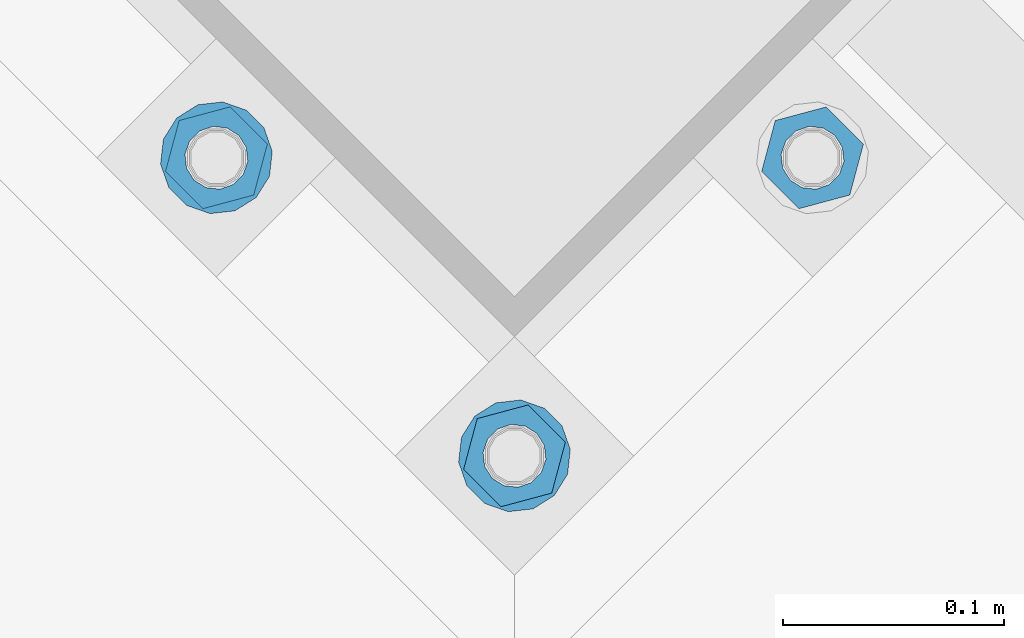
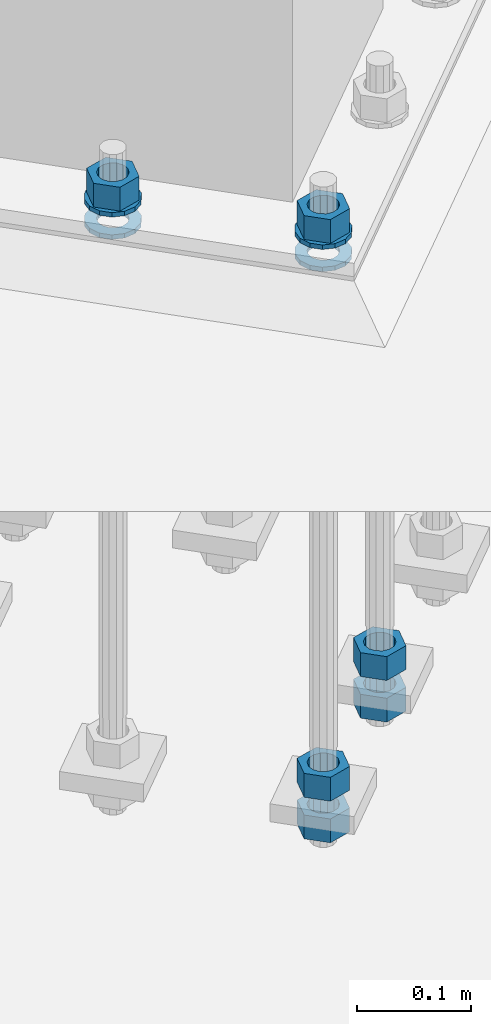
# One storey, part 877 of 1876: 10 columns, 1 element without a shape of its own.
"""IFC2X3 building model written with IfcOpenShell, lengths in millimetres."""

from ifc_helpers import new_model, si_unit, frame, origin_with_axes, place, context, subcontext, project, spatial, faceted_brep, material, type_object, element, aggregate, save


model = new_model("IFC2X3")

# Units and contexts
model_context = context("Model", 3, precision=1e-05, world=origin_with_axes())
body_context = subcontext(model_context, "Body", "Model", "MODEL_VIEW")
ifc_project = project(units=[si_unit("LENGTHUNIT", "METRE", prefix="MILLI"), si_unit("AREAUNIT", "SQUARE_METRE"), si_unit("VOLUMEUNIT", "CUBIC_METRE"), si_unit("MASSUNIT", "GRAM", prefix="KILO"), si_unit("TIMEUNIT", "SECOND"), si_unit("PLANEANGLEUNIT", "RADIAN"), si_unit("SOLIDANGLEUNIT", "STERADIAN"), si_unit("THERMODYNAMICTEMPERATUREUNIT", "DEGREE_CELSIUS"), si_unit("LUMINOUSINTENSITYUNIT", "LUMEN")], contexts=[model_context])

# Site, building, storey
site_placement = place(None, origin_with_axes())
site = spatial("IfcSite", under=ifc_project, at=site_placement, CompositionType="ELEMENT")
building_placement = place(site_placement, origin_with_axes())
building = spatial("IfcBuilding", under=site, at=building_placement, Name="Undefined", CompositionType="ELEMENT")
storey_placement = place(building_placement, origin_with_axes())
storey = spatial("IfcBuildingStorey", under=building, at=storey_placement, Name="Undefined", CompositionType="ELEMENT", Elevation=0.0)

# Assembly, columns
assembly_placement = place(storey_placement, origin_with_axes())
assembly = element("IfcElementAssembly", 1, at=assembly_placement, inside=storey, Name="TEMPLATE", AssemblyPlace="NOTDEFINED", PredefinedType="RIGID_FRAME")
ifc_material_1 = material(Name="STEEL/A563")
column_type_1 = type_object("IfcColumnType", Name="1_HEAVY_HEX_NUT", PredefinedType="NOTDEFINED")
column_1_placement = place(assembly_placement, frame((3917.62933032491, -11071.081667744, -508.0), z_axis=(0.707106781186548, 0.707106781186547, 0.0), x_axis=(0.0, 0.0, -1.0)))
column_1 = element("IfcColumn", 2, at=column_1_placement, type_object=column_type_1, material=ifc_material_1, Name="NUT", ObjectType="1_HEAVY_HEX_NUT", context=body_context, shape_type="Brep", body=[
    faceted_brep([(0.0, -23.8099994659442, 9.09494701772928e-13), (0.0, -11.9099998474121, -20.6200008392352), (25.4, -11.9099998474157, -20.6200008392361), (25.4, -23.8099994659478, 0.0), (0.0, 11.9099998474157, -20.620000839237), (25.4, 11.9099998474121, -20.620000839237), (0.0, 23.8099994659478, 9.09494701772928e-13), (25.4, 23.8099994659442, 0.0), (0.0, 11.9099998474157, 20.620000839237), (25.4, 11.9099998474121, 20.620000839237), (0.0, -11.9099998474121, 20.6200008392389), (25.4, -11.9099998474157, 20.6200008392379), (0.0, 1.81898940354586e-12, 14.2899999618567), (0.0, 6.20019861543915, 12.8748450879584), (25.4, 6.20019861543733, 12.8748450879593), (25.4, 0.0, 14.2899999618558), (0.0, 11.1723718546473, 8.90966924477925), (25.4, 11.1723718546436, 8.90966924477925), (0.0, 13.9317198278914, 3.17982413774916), (25.4, 13.9317198278877, 3.17982413775007), (0.0, 13.9317198278914, -3.17982413774644), (25.4, 13.9317198278895, -3.17982413774735), (0.0, 11.1723718546473, -8.90966924477834), (25.4, 11.1723718546455, -8.90966924477925), (0.0, 6.20019861544279, -12.8748450879575), (25.4, 6.20019861543915, -12.8748450879584), (0.0, 3.63797880709171e-12, -14.2899999618548), (25.4, -3.63797880709171e-12, -14.2899999618548), (0.0, -6.20019861543733, -12.8748450879566), (25.4, -6.20019861544097, -12.8748450879584), (0.0, -11.1723718546455, -8.90966924477743), (25.4, -11.1723718546473, -8.90966924477834), (0.0, -13.9317198278877, -3.17982413774735), (25.4, -13.9317198278914, -3.17982413774826), (0.0, -13.9317198278895, 3.17982413774735), (25.4, -13.9317198278914, 3.17982413774826), (0.0, -11.1723718546455, 8.90966924477925), (25.4, -11.1723718546473, 8.90966924478016), (0.0, -6.20019861543915, 12.8748450879593), (25.4, -6.20019861544279, 12.8748450879593)], [[[0, 1, 2, 3]], [[1, 4, 5, 2]], [[4, 6, 7, 5]], [[6, 8, 9, 7]], [[8, 10, 11, 9]], [[10, 0, 3, 11]], [[12, 13, 14, 15]], [[13, 16, 17, 14]], [[16, 18, 19, 17]], [[18, 20, 21, 19]], [[20, 22, 23, 21]], [[22, 24, 25, 23]], [[24, 26, 27, 25]], [[26, 28, 29, 27]], [[28, 30, 31, 29]], [[30, 32, 33, 31]], [[32, 34, 35, 33]], [[34, 36, 37, 35]], [[36, 38, 39, 37]], [[38, 12, 15, 39]], [[5, 7, 9, 11, 3, 2], [17, 19, 21, 23, 25, 27, 29, 31, 33, 35, 37, 39, 15, 14]], [[10, 8, 6, 4, 1, 0], [38, 36, 34, 32, 30, 28, 26, 24, 22, 20, 18, 16, 13, 12]]]),
])
column_2_placement = place(assembly_placement, frame((3917.62933032491, -11071.081667744, -552.45), z_axis=(0.707106781186548, 0.707106781186547, 0.0), x_axis=(0.0, 0.0, -1.0)))
column_2 = element("IfcColumn", 3, at=column_2_placement, type_object=column_type_1, material=ifc_material_1, Name="NUT", ObjectType="1_HEAVY_HEX_NUT", context=body_context, shape_type="Brep", body=[
    faceted_brep([(0.0, -23.8099994659442, 9.09494701772928e-13), (0.0, -11.9099998474121, -20.6200008392352), (25.4, -11.9099998474157, -20.6200008392361), (25.4, -23.8099994659478, 0.0), (0.0, 11.9099998474157, -20.620000839237), (25.4, 11.9099998474121, -20.620000839237), (0.0, 23.8099994659478, 9.09494701772928e-13), (25.4, 23.8099994659442, 0.0), (0.0, 11.9099998474157, 20.620000839237), (25.4, 11.9099998474121, 20.620000839237), (0.0, -11.9099998474121, 20.6200008392389), (25.4, -11.9099998474157, 20.6200008392379), (0.0, 1.81898940354586e-12, 14.2899999618567), (0.0, 6.20019861543915, 12.8748450879584), (25.4, 6.20019861543733, 12.8748450879593), (25.4, 0.0, 14.2899999618558), (0.0, 11.1723718546473, 8.90966924477925), (25.4, 11.1723718546436, 8.90966924477925), (0.0, 13.9317198278914, 3.17982413774916), (25.4, 13.9317198278877, 3.17982413775007), (0.0, 13.9317198278914, -3.17982413774644), (25.4, 13.9317198278895, -3.17982413774735), (0.0, 11.1723718546473, -8.90966924477834), (25.4, 11.1723718546455, -8.90966924477925), (0.0, 6.20019861544279, -12.8748450879575), (25.4, 6.20019861543915, -12.8748450879584), (0.0, 3.63797880709171e-12, -14.2899999618548), (25.4, -3.63797880709171e-12, -14.2899999618548), (0.0, -6.20019861543733, -12.8748450879566), (25.4, -6.20019861544097, -12.8748450879584), (0.0, -11.1723718546455, -8.90966924477743), (25.4, -11.1723718546473, -8.90966924477834), (0.0, -13.9317198278877, -3.17982413774735), (25.4, -13.9317198278914, -3.17982413774826), (0.0, -13.9317198278895, 3.17982413774735), (25.4, -13.9317198278914, 3.17982413774826), (0.0, -11.1723718546455, 8.90966924477925), (25.4, -11.1723718546473, 8.90966924478016), (0.0, -6.20019861543915, 12.8748450879593), (25.4, -6.20019861544279, 12.8748450879593)], [[[0, 1, 2, 3]], [[1, 4, 5, 2]], [[4, 6, 7, 5]], [[6, 8, 9, 7]], [[8, 10, 11, 9]], [[10, 0, 3, 11]], [[12, 13, 14, 15]], [[13, 16, 17, 14]], [[16, 18, 19, 17]], [[18, 20, 21, 19]], [[20, 22, 23, 21]], [[22, 24, 25, 23]], [[24, 26, 27, 25]], [[26, 28, 29, 27]], [[28, 30, 31, 29]], [[30, 32, 33, 31]], [[32, 34, 35, 33]], [[34, 36, 37, 35]], [[36, 38, 39, 37]], [[38, 12, 15, 39]], [[5, 7, 9, 11, 3, 2], [17, 19, 21, 23, 25, 27, 29, 31, 33, 35, 37, 39, 15, 14]], [[10, 8, 6, 4, 1, 0], [38, 36, 34, 32, 30, 28, 26, 24, 22, 20, 18, 16, 13, 12]]]),
])
column_3_placement = place(assembly_placement, frame((3782.92548850876, -11205.7855095602, 87.3125), z_axis=(0.707106781186548, 0.707106781186547, 0.0), x_axis=(0.0, 0.0, -1.0)))
column_3 = element("IfcColumn", 4, at=column_3_placement, type_object=column_type_1, material=ifc_material_1, Name="NUT", ObjectType="1_HEAVY_HEX_NUT", context=body_context, shape_type="Brep", body=[
    faceted_brep([(0.0, -23.8099994659442, 9.09494701772928e-13), (0.0, -11.9099998474121, -20.6200008392352), (25.4, -11.9099998474157, -20.6200008392361), (25.4, -23.8099994659478, 0.0), (0.0, 11.9099998474157, -20.620000839237), (25.4, 11.9099998474121, -20.620000839237), (0.0, 23.8099994659478, 9.09494701772928e-13), (25.4, 23.8099994659442, 0.0), (0.0, 11.9099998474157, 20.620000839237), (25.4, 11.9099998474121, 20.620000839237), (0.0, -11.9099998474121, 20.6200008392389), (25.4, -11.9099998474157, 20.6200008392379), (0.0, 1.81898940354586e-12, 14.2899999618567), (0.0, 6.20019861543915, 12.8748450879584), (25.4, 6.20019861543733, 12.8748450879593), (25.4, 0.0, 14.2899999618558), (0.0, 11.1723718546473, 8.90966924477925), (25.4, 11.1723718546436, 8.90966924477925), (0.0, 13.9317198278914, 3.17982413774916), (25.4, 13.9317198278877, 3.17982413775007), (0.0, 13.9317198278914, -3.17982413774644), (25.4, 13.9317198278895, -3.17982413774735), (0.0, 11.1723718546473, -8.90966924477834), (25.4, 11.1723718546455, -8.90966924477925), (0.0, 6.20019861544279, -12.8748450879575), (25.4, 6.20019861543915, -12.8748450879584), (0.0, 3.63797880709171e-12, -14.2899999618548), (25.4, -3.63797880709171e-12, -14.2899999618548), (0.0, -6.20019861543733, -12.8748450879566), (25.4, -6.20019861544097, -12.8748450879584), (0.0, -11.1723718546455, -8.90966924477743), (25.4, -11.1723718546473, -8.90966924477834), (0.0, -13.9317198278877, -3.17982413774735), (25.4, -13.9317198278914, -3.17982413774826), (0.0, -13.9317198278895, 3.17982413774735), (25.4, -13.9317198278914, 3.17982413774826), (0.0, -11.1723718546455, 8.90966924477925), (25.4, -11.1723718546473, 8.90966924478016), (0.0, -6.20019861543915, 12.8748450879593), (25.4, -6.20019861544279, 12.8748450879593)], [[[0, 1, 2, 3]], [[1, 4, 5, 2]], [[4, 6, 7, 5]], [[6, 8, 9, 7]], [[8, 10, 11, 9]], [[10, 0, 3, 11]], [[12, 13, 14, 15]], [[13, 16, 17, 14]], [[16, 18, 19, 17]], [[18, 20, 21, 19]], [[20, 22, 23, 21]], [[22, 24, 25, 23]], [[24, 26, 27, 25]], [[26, 28, 29, 27]], [[28, 30, 31, 29]], [[30, 32, 33, 31]], [[32, 34, 35, 33]], [[34, 36, 37, 35]], [[36, 38, 39, 37]], [[38, 12, 15, 39]], [[5, 7, 9, 11, 3, 2], [17, 19, 21, 23, 25, 27, 29, 31, 33, 35, 37, 39, 15, 14]], [[10, 8, 6, 4, 1, 0], [38, 36, 34, 32, 30, 28, 26, 24, 22, 20, 18, 16, 13, 12]]]),
])
column_4_placement = place(assembly_placement, frame((3782.92548850876, -11205.7855095602, -508.0), z_axis=(0.707106781186548, 0.707106781186547, 0.0), x_axis=(0.0, 0.0, -1.0)))
column_4 = element("IfcColumn", 5, at=column_4_placement, type_object=column_type_1, material=ifc_material_1, Name="NUT", ObjectType="1_HEAVY_HEX_NUT", context=body_context, shape_type="Brep", body=[
    faceted_brep([(0.0, -23.8099994659442, 9.09494701772928e-13), (0.0, -11.9099998474121, -20.6200008392352), (25.4, -11.9099998474157, -20.6200008392361), (25.4, -23.8099994659478, 0.0), (0.0, 11.9099998474157, -20.620000839237), (25.4, 11.9099998474121, -20.620000839237), (0.0, 23.8099994659478, 9.09494701772928e-13), (25.4, 23.8099994659442, 0.0), (0.0, 11.9099998474157, 20.620000839237), (25.4, 11.9099998474121, 20.620000839237), (0.0, -11.9099998474121, 20.6200008392389), (25.4, -11.9099998474157, 20.6200008392379), (0.0, 1.81898940354586e-12, 14.2899999618567), (0.0, 6.20019861543915, 12.8748450879584), (25.4, 6.20019861543733, 12.8748450879593), (25.4, 0.0, 14.2899999618558), (0.0, 11.1723718546473, 8.90966924477925), (25.4, 11.1723718546436, 8.90966924477925), (0.0, 13.9317198278914, 3.17982413774916), (25.4, 13.9317198278877, 3.17982413775007), (0.0, 13.9317198278914, -3.17982413774644), (25.4, 13.9317198278895, -3.17982413774735), (0.0, 11.1723718546473, -8.90966924477834), (25.4, 11.1723718546455, -8.90966924477925), (0.0, 6.20019861544279, -12.8748450879575), (25.4, 6.20019861543915, -12.8748450879584), (0.0, 3.63797880709171e-12, -14.2899999618548), (25.4, -3.63797880709171e-12, -14.2899999618548), (0.0, -6.20019861543733, -12.8748450879566), (25.4, -6.20019861544097, -12.8748450879584), (0.0, -11.1723718546455, -8.90966924477743), (25.4, -11.1723718546473, -8.90966924477834), (0.0, -13.9317198278877, -3.17982413774735), (25.4, -13.9317198278914, -3.17982413774826), (0.0, -13.9317198278895, 3.17982413774735), (25.4, -13.9317198278914, 3.17982413774826), (0.0, -11.1723718546455, 8.90966924477925), (25.4, -11.1723718546473, 8.90966924478016), (0.0, -6.20019861543915, 12.8748450879593), (25.4, -6.20019861544279, 12.8748450879593)], [[[0, 1, 2, 3]], [[1, 4, 5, 2]], [[4, 6, 7, 5]], [[6, 8, 9, 7]], [[8, 10, 11, 9]], [[10, 0, 3, 11]], [[12, 13, 14, 15]], [[13, 16, 17, 14]], [[16, 18, 19, 17]], [[18, 20, 21, 19]], [[20, 22, 23, 21]], [[22, 24, 25, 23]], [[24, 26, 27, 25]], [[26, 28, 29, 27]], [[28, 30, 31, 29]], [[30, 32, 33, 31]], [[32, 34, 35, 33]], [[34, 36, 37, 35]], [[36, 38, 39, 37]], [[38, 12, 15, 39]], [[5, 7, 9, 11, 3, 2], [17, 19, 21, 23, 25, 27, 29, 31, 33, 35, 37, 39, 15, 14]], [[10, 8, 6, 4, 1, 0], [38, 36, 34, 32, 30, 28, 26, 24, 22, 20, 18, 16, 13, 12]]]),
])
column_5_placement = place(assembly_placement, frame((3782.92548850876, -11205.7855095602, -552.45), z_axis=(0.707106781186548, 0.707106781186547, 0.0), x_axis=(0.0, 0.0, -1.0)))
column_5 = element("IfcColumn", 6, at=column_5_placement, type_object=column_type_1, material=ifc_material_1, Name="NUT", ObjectType="1_HEAVY_HEX_NUT", context=body_context, shape_type="Brep", body=[
    faceted_brep([(0.0, -23.8099994659442, 9.09494701772928e-13), (0.0, -11.9099998474121, -20.6200008392352), (25.4, -11.9099998474157, -20.6200008392361), (25.4, -23.8099994659478, 0.0), (0.0, 11.9099998474157, -20.620000839237), (25.4, 11.9099998474121, -20.620000839237), (0.0, 23.8099994659478, 9.09494701772928e-13), (25.4, 23.8099994659442, 0.0), (0.0, 11.9099998474157, 20.620000839237), (25.4, 11.9099998474121, 20.620000839237), (0.0, -11.9099998474121, 20.6200008392389), (25.4, -11.9099998474157, 20.6200008392379), (0.0, 1.81898940354586e-12, 14.2899999618567), (0.0, 6.20019861543915, 12.8748450879584), (25.4, 6.20019861543733, 12.8748450879593), (25.4, 0.0, 14.2899999618558), (0.0, 11.1723718546473, 8.90966924477925), (25.4, 11.1723718546436, 8.90966924477925), (0.0, 13.9317198278914, 3.17982413774916), (25.4, 13.9317198278877, 3.17982413775007), (0.0, 13.9317198278914, -3.17982413774644), (25.4, 13.9317198278895, -3.17982413774735), (0.0, 11.1723718546473, -8.90966924477834), (25.4, 11.1723718546455, -8.90966924477925), (0.0, 6.20019861544279, -12.8748450879575), (25.4, 6.20019861543915, -12.8748450879584), (0.0, 3.63797880709171e-12, -14.2899999618548), (25.4, -3.63797880709171e-12, -14.2899999618548), (0.0, -6.20019861543733, -12.8748450879566), (25.4, -6.20019861544097, -12.8748450879584), (0.0, -11.1723718546455, -8.90966924477743), (25.4, -11.1723718546473, -8.90966924477834), (0.0, -13.9317198278877, -3.17982413774735), (25.4, -13.9317198278914, -3.17982413774826), (0.0, -13.9317198278895, 3.17982413774735), (25.4, -13.9317198278914, 3.17982413774826), (0.0, -11.1723718546455, 8.90966924477925), (25.4, -11.1723718546473, 8.90966924478016), (0.0, -6.20019861543915, 12.8748450879593), (25.4, -6.20019861544279, 12.8748450879593)], [[[0, 1, 2, 3]], [[1, 4, 5, 2]], [[4, 6, 7, 5]], [[6, 8, 9, 7]], [[8, 10, 11, 9]], [[10, 0, 3, 11]], [[12, 13, 14, 15]], [[13, 16, 17, 14]], [[16, 18, 19, 17]], [[18, 20, 21, 19]], [[20, 22, 23, 21]], [[22, 24, 25, 23]], [[24, 26, 27, 25]], [[26, 28, 29, 27]], [[28, 30, 31, 29]], [[30, 32, 33, 31]], [[32, 34, 35, 33]], [[34, 36, 37, 35]], [[36, 38, 39, 37]], [[38, 12, 15, 39]], [[5, 7, 9, 11, 3, 2], [17, 19, 21, 23, 25, 27, 29, 31, 33, 35, 37, 39, 15, 14]], [[10, 8, 6, 4, 1, 0], [38, 36, 34, 32, 30, 28, 26, 24, 22, 20, 18, 16, 13, 12]]]),
])
column_6_placement = place(assembly_placement, frame((3648.22164669261, -11071.081667744, 87.3125), z_axis=(0.707106781186548, 0.707106781186547, 0.0), x_axis=(0.0, 0.0, -1.0)))
column_6 = element("IfcColumn", 7, at=column_6_placement, type_object=column_type_1, material=ifc_material_1, Name="NUT", ObjectType="1_HEAVY_HEX_NUT", context=body_context, shape_type="Brep", body=[
    faceted_brep([(0.0, -23.8099994659442, 9.09494701772928e-13), (0.0, -11.9099998474121, -20.6200008392352), (25.4, -11.9099998474157, -20.6200008392361), (25.4, -23.8099994659478, 0.0), (0.0, 11.9099998474157, -20.620000839237), (25.4, 11.9099998474121, -20.620000839237), (0.0, 23.8099994659478, 9.09494701772928e-13), (25.4, 23.8099994659442, 0.0), (0.0, 11.9099998474157, 20.620000839237), (25.4, 11.9099998474121, 20.620000839237), (0.0, -11.9099998474121, 20.6200008392389), (25.4, -11.9099998474157, 20.6200008392379), (0.0, 1.81898940354586e-12, 14.2899999618567), (0.0, 6.20019861543915, 12.8748450879584), (25.4, 6.20019861543733, 12.8748450879593), (25.4, 0.0, 14.2899999618558), (0.0, 11.1723718546473, 8.90966924477925), (25.4, 11.1723718546436, 8.90966924477925), (0.0, 13.9317198278914, 3.17982413774916), (25.4, 13.9317198278877, 3.17982413775007), (0.0, 13.9317198278914, -3.17982413774644), (25.4, 13.9317198278895, -3.17982413774735), (0.0, 11.1723718546473, -8.90966924477834), (25.4, 11.1723718546455, -8.90966924477925), (0.0, 6.20019861544279, -12.8748450879575), (25.4, 6.20019861543915, -12.8748450879584), (0.0, 3.63797880709171e-12, -14.2899999618548), (25.4, -3.63797880709171e-12, -14.2899999618548), (0.0, -6.20019861543733, -12.8748450879566), (25.4, -6.20019861544097, -12.8748450879584), (0.0, -11.1723718546455, -8.90966924477743), (25.4, -11.1723718546473, -8.90966924477834), (0.0, -13.9317198278877, -3.17982413774735), (25.4, -13.9317198278914, -3.17982413774826), (0.0, -13.9317198278895, 3.17982413774735), (25.4, -13.9317198278914, 3.17982413774826), (0.0, -11.1723718546455, 8.90966924477925), (25.4, -11.1723718546473, 8.90966924478016), (0.0, -6.20019861543915, 12.8748450879593), (25.4, -6.20019861544279, 12.8748450879593)], [[[0, 1, 2, 3]], [[1, 4, 5, 2]], [[4, 6, 7, 5]], [[6, 8, 9, 7]], [[8, 10, 11, 9]], [[10, 0, 3, 11]], [[12, 13, 14, 15]], [[13, 16, 17, 14]], [[16, 18, 19, 17]], [[18, 20, 21, 19]], [[20, 22, 23, 21]], [[22, 24, 25, 23]], [[24, 26, 27, 25]], [[26, 28, 29, 27]], [[28, 30, 31, 29]], [[30, 32, 33, 31]], [[32, 34, 35, 33]], [[34, 36, 37, 35]], [[36, 38, 39, 37]], [[38, 12, 15, 39]], [[5, 7, 9, 11, 3, 2], [17, 19, 21, 23, 25, 27, 29, 31, 33, 35, 37, 39, 15, 14]], [[10, 8, 6, 4, 1, 0], [38, 36, 34, 32, 30, 28, 26, 24, 22, 20, 18, 16, 13, 12]]]),
])
ifc_material_2 = material(Name="STEEL/F436")
column_type_2 = type_object("IfcColumnType", Name="1_WASHER", PredefinedType="NOTDEFINED")
column_7_placement = place(assembly_placement, frame((3782.92548850876, -11205.7855095602, 38.1), z_axis=(0.707106781186548, 0.707106781186547, 0.0), x_axis=(0.0, 0.0, -1.0)))
column_7 = element("IfcColumn", 8, at=column_7_placement, type_object=column_type_2, material=ifc_material_2, Name="WASHER", ObjectType="1_WASHER", context=body_context, shape_type="Brep", body=[
    faceted_brep([(0.0, -25.3999996185375, 0.0), (0.0, -22.8846089010331, -11.0206468080742), (4.7625, -22.8846089010331, -11.0206468080742), (4.7625, -25.3999996185375, 0.0), (0.0, -15.8366407293743, -19.8585193564477), (4.7625, -15.8366407293743, -19.8585193564477), (0.0, -5.65203163760816, -24.7631685975166), (4.7625, -5.65203163760816, -24.7631685975166), (0.0, 5.65203163760452, -24.7631685975166), (4.7625, 5.65203163760452, -24.7631685975166), (0.0, 15.8366407293706, -19.858519356445), (4.7625, 15.8366407293706, -19.858519356445), (0.0, 22.8846089010331, -11.0206468080733), (4.7625, 22.8846089010331, -11.0206468080733), (0.0, 25.3999996185339, 9.09494701772928e-13), (4.7625, 25.3999996185339, 9.09494701772928e-13), (0.0, 22.8846089010331, 11.0206468080751), (4.7625, 22.8846089010331, 11.0206468080751), (0.0, 15.8366407293706, 19.8585193564486), (4.7625, 15.8366407293706, 19.8585193564486), (0.0, 5.65203163760452, 24.7631685975175), (4.7625, 5.65203163760452, 24.7631685975175), (0.0, -5.65203163760816, 24.7631685975175), (4.7625, -5.65203163760816, 24.7631685975175), (0.0, -15.8366407293724, 19.8585193564459), (4.7625, -15.8366407293724, 19.8585193564459), (0.0, -22.8846089010367, 11.0206468080751), (4.7625, -22.8846089010367, 11.0206468080751), (0.0, 1.81898940354586e-12, 14.2899999618567), (0.0, 6.20019861543915, 12.8748450879584), (4.7625, 6.20019861543733, 12.8748450879593), (4.7625, 0.0, 14.2899999618558), (0.0, 11.1723718546473, 8.90966924477925), (4.7625, 11.1723718546436, 8.90966924477925), (0.0, 13.9317198278914, 3.17982413774916), (4.7625, 13.9317198278877, 3.17982413775007), (0.0, 13.9317198278914, -3.17982413774644), (4.7625, 13.9317198278895, -3.17982413774735), (0.0, 11.1723718546473, -8.90966924477834), (4.7625, 11.1723718546455, -8.90966924477925), (0.0, 6.20019861544279, -12.8748450879575), (4.7625, 6.20019861543915, -12.8748450879584), (0.0, 3.63797880709171e-12, -14.2899999618548), (4.7625, -3.63797880709171e-12, -14.2899999618548), (0.0, -6.20019861543733, -12.8748450879566), (4.7625, -6.20019861544097, -12.8748450879584), (0.0, -11.1723718546455, -8.90966924477743), (4.7625, -11.1723718546473, -8.90966924477834), (0.0, -13.9317198278877, -3.17982413774735), (4.7625, -13.9317198278914, -3.17982413774826), (0.0, -13.9317198278895, 3.17982413774735), (4.7625, -13.9317198278914, 3.17982413774826), (0.0, -11.1723718546455, 8.90966924477925), (4.7625, -11.1723718546473, 8.90966924478016), (0.0, -6.20019861543915, 12.8748450879593), (4.7625, -6.20019861544279, 12.8748450879593)], [[[0, 1, 2, 3]], [[1, 4, 5, 2]], [[4, 6, 7, 5]], [[6, 8, 9, 7]], [[8, 10, 11, 9]], [[10, 12, 13, 11]], [[12, 14, 15, 13]], [[14, 16, 17, 15]], [[16, 18, 19, 17]], [[18, 20, 21, 19]], [[20, 22, 23, 21]], [[22, 24, 25, 23]], [[24, 26, 27, 25]], [[26, 0, 3, 27]], [[28, 29, 30, 31]], [[29, 32, 33, 30]], [[32, 34, 35, 33]], [[34, 36, 37, 35]], [[36, 38, 39, 37]], [[38, 40, 41, 39]], [[40, 42, 43, 41]], [[42, 44, 45, 43]], [[44, 46, 47, 45]], [[46, 48, 49, 47]], [[48, 50, 51, 49]], [[50, 52, 53, 51]], [[52, 54, 55, 53]], [[54, 28, 31, 55]], [[5, 7, 9, 11, 13, 15, 17, 19, 21, 23, 25, 27, 3, 2], [33, 35, 37, 39, 41, 43, 45, 47, 49, 51, 53, 55, 31, 30]], [[26, 24, 22, 20, 18, 16, 14, 12, 10, 8, 6, 4, 1, 0], [54, 52, 50, 48, 46, 44, 42, 40, 38, 36, 34, 32, 29, 28]]]),
])
column_8_placement = place(assembly_placement, frame((3782.92548850876, -11205.7855095602, 61.9125), z_axis=(0.707106781186548, 0.707106781186547, 0.0), x_axis=(0.0, 0.0, -1.0)))
column_8 = element("IfcColumn", 9, at=column_8_placement, type_object=column_type_2, material=ifc_material_2, Name="WASHER", ObjectType="1_WASHER", context=body_context, shape_type="Brep", body=[
    faceted_brep([(0.0, -25.3999996185375, 0.0), (0.0, -22.8846089010331, -11.0206468080742), (4.7625, -22.8846089010331, -11.0206468080742), (4.7625, -25.3999996185375, 0.0), (0.0, -15.8366407293743, -19.8585193564477), (4.7625, -15.8366407293743, -19.8585193564477), (0.0, -5.65203163760816, -24.7631685975166), (4.7625, -5.65203163760816, -24.7631685975166), (0.0, 5.65203163760452, -24.7631685975166), (4.7625, 5.65203163760452, -24.7631685975166), (0.0, 15.8366407293706, -19.858519356445), (4.7625, 15.8366407293706, -19.858519356445), (0.0, 22.8846089010331, -11.0206468080733), (4.7625, 22.8846089010331, -11.0206468080733), (0.0, 25.3999996185339, 9.09494701772928e-13), (4.7625, 25.3999996185339, 9.09494701772928e-13), (0.0, 22.8846089010331, 11.0206468080751), (4.7625, 22.8846089010331, 11.0206468080751), (0.0, 15.8366407293706, 19.8585193564486), (4.7625, 15.8366407293706, 19.8585193564486), (0.0, 5.65203163760452, 24.7631685975175), (4.7625, 5.65203163760452, 24.7631685975175), (0.0, -5.65203163760816, 24.7631685975175), (4.7625, -5.65203163760816, 24.7631685975175), (0.0, -15.8366407293724, 19.8585193564459), (4.7625, -15.8366407293724, 19.8585193564459), (0.0, -22.8846089010367, 11.0206468080751), (4.7625, -22.8846089010367, 11.0206468080751), (0.0, 1.81898940354586e-12, 14.2899999618567), (0.0, 6.20019861543915, 12.8748450879584), (4.7625, 6.20019861543733, 12.8748450879593), (4.7625, 0.0, 14.2899999618558), (0.0, 11.1723718546473, 8.90966924477925), (4.7625, 11.1723718546436, 8.90966924477925), (0.0, 13.9317198278914, 3.17982413774916), (4.7625, 13.9317198278877, 3.17982413775007), (0.0, 13.9317198278914, -3.17982413774644), (4.7625, 13.9317198278895, -3.17982413774735), (0.0, 11.1723718546473, -8.90966924477834), (4.7625, 11.1723718546455, -8.90966924477925), (0.0, 6.20019861544279, -12.8748450879575), (4.7625, 6.20019861543915, -12.8748450879584), (0.0, 3.63797880709171e-12, -14.2899999618548), (4.7625, -3.63797880709171e-12, -14.2899999618548), (0.0, -6.20019861543733, -12.8748450879566), (4.7625, -6.20019861544097, -12.8748450879584), (0.0, -11.1723718546455, -8.90966924477743), (4.7625, -11.1723718546473, -8.90966924477834), (0.0, -13.9317198278877, -3.17982413774735), (4.7625, -13.9317198278914, -3.17982413774826), (0.0, -13.9317198278895, 3.17982413774735), (4.7625, -13.9317198278914, 3.17982413774826), (0.0, -11.1723718546455, 8.90966924477925), (4.7625, -11.1723718546473, 8.90966924478016), (0.0, -6.20019861543915, 12.8748450879593), (4.7625, -6.20019861544279, 12.8748450879593)], [[[0, 1, 2, 3]], [[1, 4, 5, 2]], [[4, 6, 7, 5]], [[6, 8, 9, 7]], [[8, 10, 11, 9]], [[10, 12, 13, 11]], [[12, 14, 15, 13]], [[14, 16, 17, 15]], [[16, 18, 19, 17]], [[18, 20, 21, 19]], [[20, 22, 23, 21]], [[22, 24, 25, 23]], [[24, 26, 27, 25]], [[26, 0, 3, 27]], [[28, 29, 30, 31]], [[29, 32, 33, 30]], [[32, 34, 35, 33]], [[34, 36, 37, 35]], [[36, 38, 39, 37]], [[38, 40, 41, 39]], [[40, 42, 43, 41]], [[42, 44, 45, 43]], [[44, 46, 47, 45]], [[46, 48, 49, 47]], [[48, 50, 51, 49]], [[50, 52, 53, 51]], [[52, 54, 55, 53]], [[54, 28, 31, 55]], [[5, 7, 9, 11, 13, 15, 17, 19, 21, 23, 25, 27, 3, 2], [33, 35, 37, 39, 41, 43, 45, 47, 49, 51, 53, 55, 31, 30]], [[26, 24, 22, 20, 18, 16, 14, 12, 10, 8, 6, 4, 1, 0], [54, 52, 50, 48, 46, 44, 42, 40, 38, 36, 34, 32, 29, 28]]]),
])
column_9_placement = place(assembly_placement, frame((3648.22164669261, -11071.081667744, 38.1), z_axis=(0.707106781186548, 0.707106781186547, 0.0), x_axis=(0.0, 0.0, -1.0)))
column_9 = element("IfcColumn", 10, at=column_9_placement, type_object=column_type_2, material=ifc_material_2, Name="WASHER", ObjectType="1_WASHER", context=body_context, shape_type="Brep", body=[
    faceted_brep([(0.0, -25.3999996185375, 0.0), (0.0, -22.8846089010331, -11.0206468080742), (4.7625, -22.8846089010331, -11.0206468080742), (4.7625, -25.3999996185375, 0.0), (0.0, -15.8366407293743, -19.8585193564477), (4.7625, -15.8366407293743, -19.8585193564477), (0.0, -5.65203163760816, -24.7631685975166), (4.7625, -5.65203163760816, -24.7631685975166), (0.0, 5.65203163760452, -24.7631685975166), (4.7625, 5.65203163760452, -24.7631685975166), (0.0, 15.8366407293706, -19.858519356445), (4.7625, 15.8366407293706, -19.858519356445), (0.0, 22.8846089010331, -11.0206468080733), (4.7625, 22.8846089010331, -11.0206468080733), (0.0, 25.3999996185339, 9.09494701772928e-13), (4.7625, 25.3999996185339, 9.09494701772928e-13), (0.0, 22.8846089010331, 11.0206468080751), (4.7625, 22.8846089010331, 11.0206468080751), (0.0, 15.8366407293706, 19.8585193564486), (4.7625, 15.8366407293706, 19.8585193564486), (0.0, 5.65203163760452, 24.7631685975175), (4.7625, 5.65203163760452, 24.7631685975175), (0.0, -5.65203163760816, 24.7631685975175), (4.7625, -5.65203163760816, 24.7631685975175), (0.0, -15.8366407293724, 19.8585193564459), (4.7625, -15.8366407293724, 19.8585193564459), (0.0, -22.8846089010367, 11.0206468080751), (4.7625, -22.8846089010367, 11.0206468080751), (0.0, 1.81898940354586e-12, 14.2899999618567), (0.0, 6.20019861543915, 12.8748450879584), (4.7625, 6.20019861543733, 12.8748450879593), (4.7625, 0.0, 14.2899999618558), (0.0, 11.1723718546473, 8.90966924477925), (4.7625, 11.1723718546436, 8.90966924477925), (0.0, 13.9317198278914, 3.17982413774916), (4.7625, 13.9317198278877, 3.17982413775007), (0.0, 13.9317198278914, -3.17982413774644), (4.7625, 13.9317198278895, -3.17982413774735), (0.0, 11.1723718546473, -8.90966924477834), (4.7625, 11.1723718546455, -8.90966924477925), (0.0, 6.20019861544279, -12.8748450879575), (4.7625, 6.20019861543915, -12.8748450879584), (0.0, 3.63797880709171e-12, -14.2899999618548), (4.7625, -3.63797880709171e-12, -14.2899999618548), (0.0, -6.20019861543733, -12.8748450879566), (4.7625, -6.20019861544097, -12.8748450879584), (0.0, -11.1723718546455, -8.90966924477743), (4.7625, -11.1723718546473, -8.90966924477834), (0.0, -13.9317198278877, -3.17982413774735), (4.7625, -13.9317198278914, -3.17982413774826), (0.0, -13.9317198278895, 3.17982413774735), (4.7625, -13.9317198278914, 3.17982413774826), (0.0, -11.1723718546455, 8.90966924477925), (4.7625, -11.1723718546473, 8.90966924478016), (0.0, -6.20019861543915, 12.8748450879593), (4.7625, -6.20019861544279, 12.8748450879593)], [[[0, 1, 2, 3]], [[1, 4, 5, 2]], [[4, 6, 7, 5]], [[6, 8, 9, 7]], [[8, 10, 11, 9]], [[10, 12, 13, 11]], [[12, 14, 15, 13]], [[14, 16, 17, 15]], [[16, 18, 19, 17]], [[18, 20, 21, 19]], [[20, 22, 23, 21]], [[22, 24, 25, 23]], [[24, 26, 27, 25]], [[26, 0, 3, 27]], [[28, 29, 30, 31]], [[29, 32, 33, 30]], [[32, 34, 35, 33]], [[34, 36, 37, 35]], [[36, 38, 39, 37]], [[38, 40, 41, 39]], [[40, 42, 43, 41]], [[42, 44, 45, 43]], [[44, 46, 47, 45]], [[46, 48, 49, 47]], [[48, 50, 51, 49]], [[50, 52, 53, 51]], [[52, 54, 55, 53]], [[54, 28, 31, 55]], [[5, 7, 9, 11, 13, 15, 17, 19, 21, 23, 25, 27, 3, 2], [33, 35, 37, 39, 41, 43, 45, 47, 49, 51, 53, 55, 31, 30]], [[26, 24, 22, 20, 18, 16, 14, 12, 10, 8, 6, 4, 1, 0], [54, 52, 50, 48, 46, 44, 42, 40, 38, 36, 34, 32, 29, 28]]]),
])
column_10_placement = place(assembly_placement, frame((3648.22164669261, -11071.081667744, 61.9125), z_axis=(0.707106781186548, 0.707106781186547, 0.0), x_axis=(0.0, 0.0, -1.0)))
column_10 = element("IfcColumn", 11, at=column_10_placement, type_object=column_type_2, material=ifc_material_2, Name="WASHER", ObjectType="1_WASHER", context=body_context, shape_type="Brep", body=[
    faceted_brep([(0.0, -25.3999996185375, 0.0), (0.0, -22.8846089010331, -11.0206468080742), (4.7625, -22.8846089010331, -11.0206468080742), (4.7625, -25.3999996185375, 0.0), (0.0, -15.8366407293743, -19.8585193564477), (4.7625, -15.8366407293743, -19.8585193564477), (0.0, -5.65203163760816, -24.7631685975166), (4.7625, -5.65203163760816, -24.7631685975166), (0.0, 5.65203163760452, -24.7631685975166), (4.7625, 5.65203163760452, -24.7631685975166), (0.0, 15.8366407293706, -19.858519356445), (4.7625, 15.8366407293706, -19.858519356445), (0.0, 22.8846089010331, -11.0206468080733), (4.7625, 22.8846089010331, -11.0206468080733), (0.0, 25.3999996185339, 9.09494701772928e-13), (4.7625, 25.3999996185339, 9.09494701772928e-13), (0.0, 22.8846089010331, 11.0206468080751), (4.7625, 22.8846089010331, 11.0206468080751), (0.0, 15.8366407293706, 19.8585193564486), (4.7625, 15.8366407293706, 19.8585193564486), (0.0, 5.65203163760452, 24.7631685975175), (4.7625, 5.65203163760452, 24.7631685975175), (0.0, -5.65203163760816, 24.7631685975175), (4.7625, -5.65203163760816, 24.7631685975175), (0.0, -15.8366407293724, 19.8585193564459), (4.7625, -15.8366407293724, 19.8585193564459), (0.0, -22.8846089010367, 11.0206468080751), (4.7625, -22.8846089010367, 11.0206468080751), (0.0, 1.81898940354586e-12, 14.2899999618567), (0.0, 6.20019861543915, 12.8748450879584), (4.7625, 6.20019861543733, 12.8748450879593), (4.7625, 0.0, 14.2899999618558), (0.0, 11.1723718546473, 8.90966924477925), (4.7625, 11.1723718546436, 8.90966924477925), (0.0, 13.9317198278914, 3.17982413774916), (4.7625, 13.9317198278877, 3.17982413775007), (0.0, 13.9317198278914, -3.17982413774644), (4.7625, 13.9317198278895, -3.17982413774735), (0.0, 11.1723718546473, -8.90966924477834), (4.7625, 11.1723718546455, -8.90966924477925), (0.0, 6.20019861544279, -12.8748450879575), (4.7625, 6.20019861543915, -12.8748450879584), (0.0, 3.63797880709171e-12, -14.2899999618548), (4.7625, -3.63797880709171e-12, -14.2899999618548), (0.0, -6.20019861543733, -12.8748450879566), (4.7625, -6.20019861544097, -12.8748450879584), (0.0, -11.1723718546455, -8.90966924477743), (4.7625, -11.1723718546473, -8.90966924477834), (0.0, -13.9317198278877, -3.17982413774735), (4.7625, -13.9317198278914, -3.17982413774826), (0.0, -13.9317198278895, 3.17982413774735), (4.7625, -13.9317198278914, 3.17982413774826), (0.0, -11.1723718546455, 8.90966924477925), (4.7625, -11.1723718546473, 8.90966924478016), (0.0, -6.20019861543915, 12.8748450879593), (4.7625, -6.20019861544279, 12.8748450879593)], [[[0, 1, 2, 3]], [[1, 4, 5, 2]], [[4, 6, 7, 5]], [[6, 8, 9, 7]], [[8, 10, 11, 9]], [[10, 12, 13, 11]], [[12, 14, 15, 13]], [[14, 16, 17, 15]], [[16, 18, 19, 17]], [[18, 20, 21, 19]], [[20, 22, 23, 21]], [[22, 24, 25, 23]], [[24, 26, 27, 25]], [[26, 0, 3, 27]], [[28, 29, 30, 31]], [[29, 32, 33, 30]], [[32, 34, 35, 33]], [[34, 36, 37, 35]], [[36, 38, 39, 37]], [[38, 40, 41, 39]], [[40, 42, 43, 41]], [[42, 44, 45, 43]], [[44, 46, 47, 45]], [[46, 48, 49, 47]], [[48, 50, 51, 49]], [[50, 52, 53, 51]], [[52, 54, 55, 53]], [[54, 28, 31, 55]], [[5, 7, 9, 11, 13, 15, 17, 19, 21, 23, 25, 27, 3, 2], [33, 35, 37, 39, 41, 43, 45, 47, 49, 51, 53, 55, 31, 30]], [[26, 24, 22, 20, 18, 16, 14, 12, 10, 8, 6, 4, 1, 0], [54, 52, 50, 48, 46, 44, 42, 40, 38, 36, 34, 32, 29, 28]]]),
])
aggregate(assembly, [column_1, column_2, column_3, column_7, column_8, column_4, column_5, column_6, column_9, column_10])

save(model, "model.ifc")
